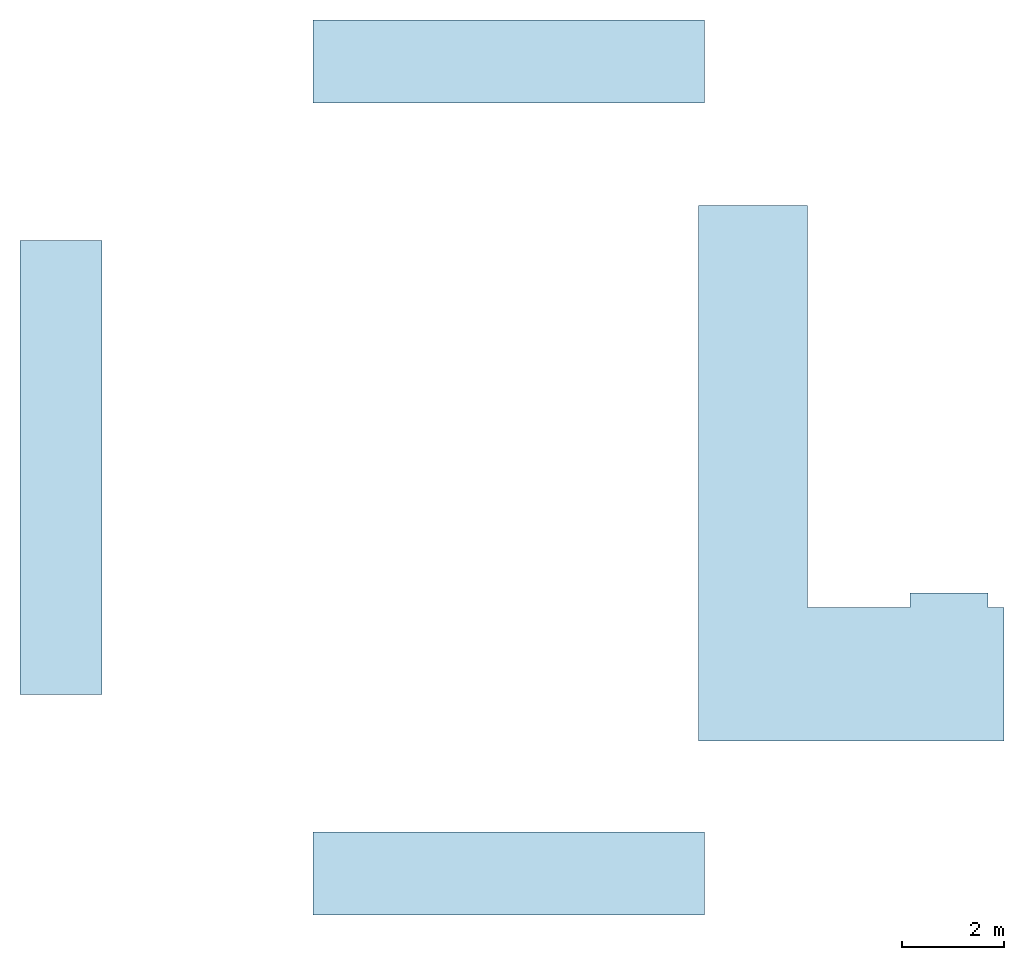
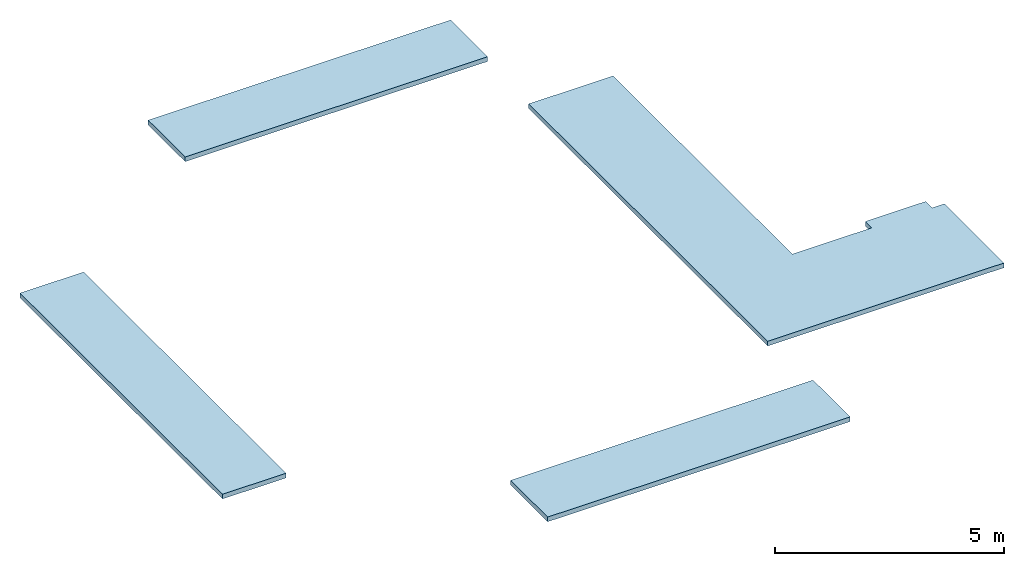
# One storey: 4 slabs.
"""IFC2X3 building model written with IfcOpenShell, lengths in millimetres."""

from ifc_helpers import new_model, entity, si_unit, converted_unit, derived_unit, direction, frame, frame_2d, origin, place, context, subcontext, project, spatial, polyline, rectangle, outline, extrude, material, layer, layer_set, layer_usage, type_object, element, save


model = new_model("IFC2X3")

# Units and contexts
model_context = context("Model", 3, precision=0.01, world=origin(), true_north=direction((6.12303176911189e-17, 1.0)))
body_context = subcontext(model_context, "Body", "Model", "MODEL_VIEW")
ifc_project = project(units=[si_unit("LENGTHUNIT", "METRE", prefix="MILLI"), si_unit("AREAUNIT", "SQUARE_METRE"), si_unit("VOLUMEUNIT", "CUBIC_METRE"), converted_unit("PLANEANGLEUNIT", "DEGREE", entity("IfcRatioMeasure", 0.0174532925199433), si_unit("PLANEANGLEUNIT", "RADIAN"), dimensions=[0, 0, 0, 0, 0, 0, 0]), si_unit("MASSUNIT", "GRAM", prefix="KILO"), derived_unit("MASSDENSITYUNIT", [(si_unit("MASSUNIT", "GRAM", prefix="KILO"), 1), (si_unit("LENGTHUNIT", "METRE"), -3)]), si_unit("TIMEUNIT", "SECOND"), si_unit("FREQUENCYUNIT", "HERTZ"), si_unit("THERMODYNAMICTEMPERATUREUNIT", "DEGREE_CELSIUS"), derived_unit("THERMALTRANSMITTANCEUNIT", [(si_unit("MASSUNIT", "GRAM", prefix="KILO"), 1), (si_unit("THERMODYNAMICTEMPERATUREUNIT", "KELVIN"), -1), (si_unit("TIMEUNIT", "SECOND"), -3)]), derived_unit("VOLUMETRICFLOWRATEUNIT", [(si_unit("LENGTHUNIT", "METRE"), 3), (si_unit("TIMEUNIT", "SECOND"), -1)]), si_unit("ELECTRICCURRENTUNIT", "AMPERE"), si_unit("ELECTRICVOLTAGEUNIT", "VOLT"), si_unit("POWERUNIT", "WATT"), si_unit("FORCEUNIT", "NEWTON", prefix="KILO"), si_unit("ILLUMINANCEUNIT", "LUX"), si_unit("LUMINOUSFLUXUNIT", "LUMEN"), si_unit("LUMINOUSINTENSITYUNIT", "CANDELA"), derived_unit("USERDEFINED", [(si_unit("MASSUNIT", "GRAM", prefix="KILO"), -1), (si_unit("LENGTHUNIT", "METRE"), -2), (si_unit("TIMEUNIT", "SECOND"), 3), (si_unit("LUMINOUSFLUXUNIT", "LUMEN"), 1)]), derived_unit("LINEARVELOCITYUNIT", [(si_unit("LENGTHUNIT", "METRE"), 1), (si_unit("TIMEUNIT", "SECOND"), -1)]), si_unit("PRESSUREUNIT", "PASCAL"), derived_unit("USERDEFINED", [(si_unit("LENGTHUNIT", "METRE"), -2), (si_unit("MASSUNIT", "GRAM", prefix="KILO"), 1), (si_unit("TIMEUNIT", "SECOND"), -2)])], contexts=[model_context])

# Site, building, storey
site_placement = place(None, origin())
site = spatial("IfcSite", under=ifc_project, at=site_placement, CompositionType="ELEMENT")
building_placement = place(site_placement, origin())
building = spatial("IfcBuilding", under=site, at=building_placement, CompositionType="ELEMENT")
storey_placement = place(building_placement, frame((0.0, 0.0, 16000.0)))
storey = spatial("IfcBuildingStorey", under=building, at=storey_placement, Name="04 Roof", CompositionType="ELEMENT", Elevation=16000.0)

# Slabs
ifc_material_1 = material()
ifc_layer_1 = layer(ifc_material_1, 110.0)
ifc_material_2 = material(Name="03")
ifc_layer_2 = layer(ifc_material_2, 15.0)
ifc_layer_set = layer_set([ifc_layer_1, ifc_layer_2], Name="Floor")
ifc_layer_usage_1 = layer_usage(ifc_layer_set, "AXIS3", "POSITIVE", 0.0)
slab_type_1 = type_object("IfcSlabType", Name="Floor", PredefinedType="FLOOR")
slab_1_placement = place(storey_placement, frame((15568.4900708517, -77571.2395851399, -465.0)))
element("IfcSlab", 1, at=slab_1_placement, inside=storey, type_object=slab_type_1, material=ifc_layer_usage_1, Name="Floor", ObjectType="Floor", PredefinedType="FLOOR", context=body_context, shape_type="SweptSolid", body=[
    extrude(rectangle(XDim=7640.0, YDim=1620.0, at=frame_2d((-2862.50000000001, -7930.0), x_axis=(-1.0, 0.0))), frame((6682.50000000003, 8740.0, 125.0), z_axis=(0.0, 0.0, -1.0), x_axis=(-1.0, 0.0, 0.0)), (0.0, 0.0, 1.0), 125.0),
])
slab_type_2 = type_object("IfcSlabType", Name="Floor", PredefinedType="FLOOR")
slab_2_placement = place(storey_placement, frame((15568.4900708517, -77571.2395851399, -465.0)))
element("IfcSlab", 2, at=slab_2_placement, inside=storey, type_object=slab_type_2, material=ifc_layer_usage_1, Name="Floor:2", ObjectType="Floor", PredefinedType="FLOOR", context=body_context, shape_type="SweptSolid", body=[
    extrude(rectangle(XDim=8859.99999999999, YDim=1605.00000000003, at=frame_2d((5880.0, 0.0), x_axis=(0.0, 1.0))), frame((6682.50000000003, 8740.0, 125.0), z_axis=(0.0, 0.0, -1.0), x_axis=(-1.0, 0.0, 0.0)), (0.0, 0.0, 1.0), 125.0),
])
slab_type_3 = type_object("IfcSlabType", Name="Floor", PredefinedType="FLOOR", material=ifc_layer_set)
slab_3_placement = place(storey_placement, frame((15568.4900708517, -77571.2395851399, -465.0)))
element("IfcSlab", 3, at=slab_3_placement, inside=storey, type_object=slab_type_3, material=ifc_layer_usage_1, Name="Floor:3", ObjectType="Floor", PredefinedType="FLOOR", context=body_context, shape_type="SweptSolid", body=[
    extrude(rectangle(XDim=1619.99999999997, YDim=7639.99999999997, at=frame_2d((-2862.50000000004, 7930.0), x_axis=(0.0, 1.0))), frame((6682.50000000003, 8740.0, 125.0), z_axis=(0.0, 0.0, -1.0), x_axis=(-1.0, 0.0, 0.0)), (0.0, 0.0, 1.0), 125.0),
])
ifc_layer_usage_2 = layer_usage(ifc_layer_set, "AXIS3", "POSITIVE", 0.0)
slab_type_4 = type_object("IfcSlabType", Name="Floor", PredefinedType="FLOOR", material=ifc_layer_set)
slab_4_placement = place(storey_placement, origin())
element("IfcSlab", 4, at=slab_4_placement, inside=storey, type_object=slab_type_4, material=ifc_layer_usage_2, Name="Floor", ObjectType="Floor", PredefinedType="FLOOR", context=body_context, shape_type="SweptSolid", body=[
    extrude(outline(polyline([(-3713.0, -3578.83630606416), (6742.0, -3578.83630606416), (6742.0, -1448.83630606415), (-1103.0, -1448.83630606415), (-1103.0, 555.345224256676), (-823.0, 555.345224256676), (-823.0, 2081.16369393581), (-1103.0, 2081.16369393581), (-1103.0, 2391.16369393581), (-3713.0, 2391.16369393581), (-3713.0, -3578.83630606416)])), frame((32392.326376916, -70457.8241905963, -340.0), z_axis=(0.0, 0.0, -1.0), x_axis=(0.0, 1.0, 0.0)), (0.0, 0.0, 1.0), 125.0),
])

save(model, "model.ifc")
